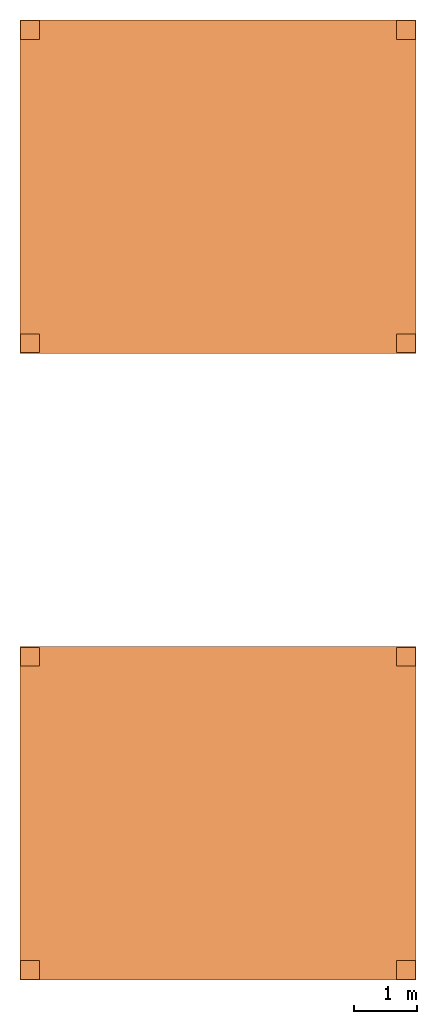
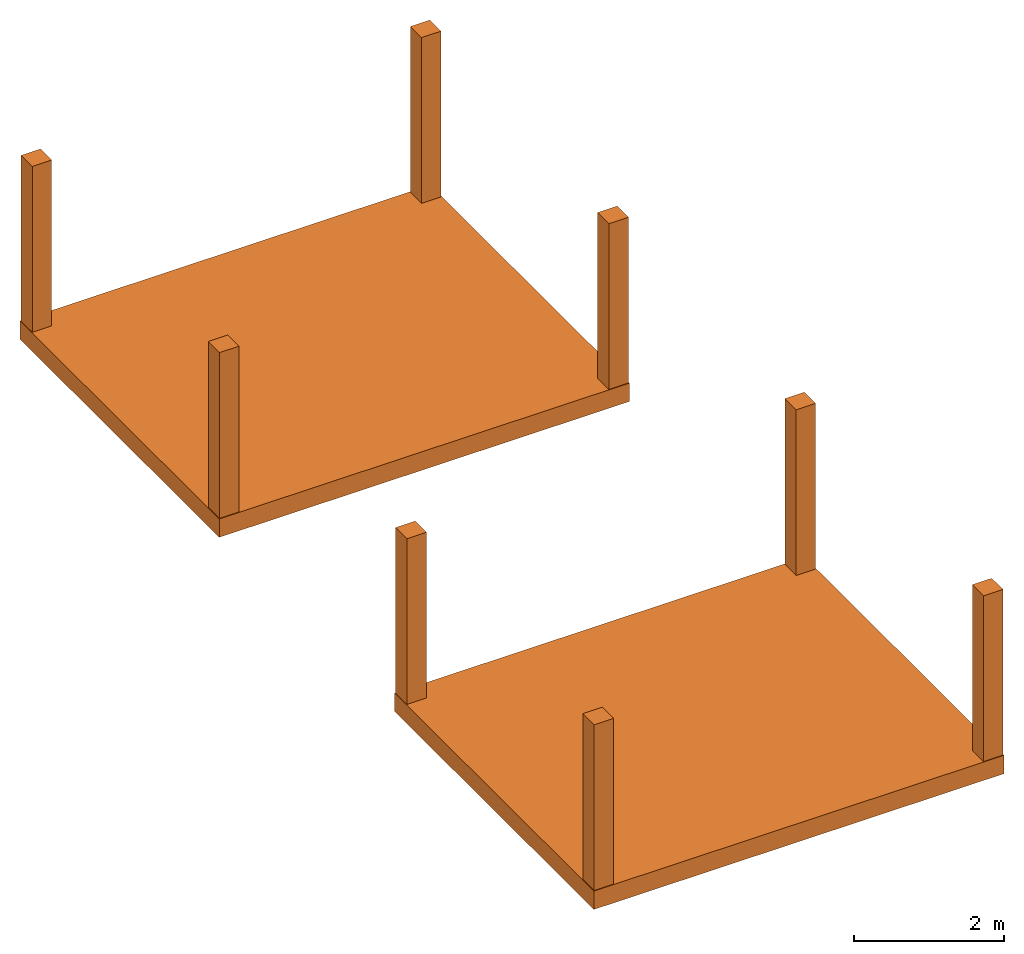
# One storey: 10 proxies.
"""IFC2X3 building model written with IfcOpenShell, lengths in metres."""

from ifc_helpers import new_model, entity, si_unit, converted_unit, derived_unit, money_unit, direction, frame, origin_with_axes, origin_2d_with_axis, place, context, subcontext, project, spatial, polyline, rectangle, outline, extrude, material, type_object, element, save


model = new_model("IFC2X3")

# Units and contexts
model_context = context("Model", 3, precision=1e-05, world=origin_with_axes(), true_north=direction((0.0, 1.0)))
body_context = subcontext(model_context, "Body", "Model", "MODEL_VIEW")
ifc_project = project(units=[si_unit("LENGTHUNIT", "METRE"), si_unit("AREAUNIT", "SQUARE_METRE"), si_unit("VOLUMEUNIT", "CUBIC_METRE"), converted_unit("PLANEANGLEUNIT", "DEGREE", entity("IfcPlaneAngleMeasure", 0.0174532925199433), si_unit("PLANEANGLEUNIT", "RADIAN"), dimensions=[0, 0, 0, 0, 0, 0, 0]), money_unit("EUR"), converted_unit("TIMEUNIT", "Year", entity("IfcTimeMeasure", 31557600.0), si_unit("TIMEUNIT", "SECOND"), dimensions=[0, 0, 1, 0, 0, 0, 0]), si_unit("MASSUNIT", "GRAM", prefix="KILO"), si_unit("THERMODYNAMICTEMPERATUREUNIT", "DEGREE_CELSIUS"), si_unit("LUMINOUSINTENSITYUNIT", "LUMEN"), si_unit("ENERGYUNIT", "JOULE", prefix="MEGA"), derived_unit("THERMALCONDUCTANCEUNIT", [(si_unit("POWERUNIT", "WATT"), 1), (si_unit("LENGTHUNIT", "METRE"), -1), (si_unit("THERMODYNAMICTEMPERATUREUNIT", "KELVIN"), -1)]), derived_unit("SPECIFICHEATCAPACITYUNIT", [(si_unit("ENERGYUNIT", "JOULE"), 1), (si_unit("MASSUNIT", "GRAM", prefix="KILO"), -1), (si_unit("THERMODYNAMICTEMPERATUREUNIT", "KELVIN"), -1)]), derived_unit("MASSDENSITYUNIT", [(si_unit("MASSUNIT", "GRAM", prefix="KILO"), 1), (si_unit("VOLUMEUNIT", "CUBIC_METRE"), -1)])], contexts=[model_context])

# Site, building, storey
site_placement = place(None, origin_with_axes())
site = spatial("IfcSite", under=ifc_project, at=site_placement, CompositionType="ELEMENT")
building_placement = place(site_placement, origin_with_axes())
building = spatial("IfcBuilding", under=site, at=building_placement, Name="Edificio", CompositionType="ELEMENT")
storey_placement = place(building_placement, frame((0.0, 0.0, 6.0), z_axis=(0.0, 0.0, 1.0), x_axis=(1.0, 0.0, 0.0)))
storey = spatial("IfcBuildingStorey", under=building, at=storey_placement, Name="L02", CompositionType="ELEMENT", Elevation=6.0)

# Proxies
ifc_material_1 = material(Name="Cemento - Strutturale")
building_element_proxy_type_1 = type_object("IfcBuildingElementProxyType", Name="Cemento - Strutturale 300", PredefinedType="NOTDEFINED")
for number, where, z_axis, x_axis, name in (
    (1, (-0.16, -0.16, 0.0), (0.0, 0.0, 1.0), (1.0, 0.0, 0.0), "SOL_002"),
    (2, (-0.1599999999999991, 9.84, 0.0), (0.0, 0.0, 1.0), (1.0, 0.0, 0.0), "SOL_006"),
):
    element("IfcBuildingElementProxy", number, at=place(storey_placement, frame(where, z_axis=z_axis, x_axis=x_axis)), inside=storey, type_object=building_element_proxy_type_1, material=ifc_material_1, Name=name, context=body_context, shape_type="SweptSolid", body=[
        extrude(outline(polyline([(0.0, 0.0), (6.32, 0.0), (6.32, 5.32), (0.0, 5.32), (0.0, 0.0)])), frame((0.0, 0.0, -0.3), z_axis=(0.0, 0.0, 1.0), x_axis=(1.0, 0.0, 0.0)), (0.0, 0.0, 1.0), 0.3),
    ])
ifc_material_2 = material(Name="Cemento Strutturale")
building_element_proxy_type_2 = type_object("IfcBuildingElementProxyType", Name="Cemento Strutturale 300 x 300", PredefinedType="NOTDEFINED")
for number, where, z_axis, x_axis, name in (
    (3, (6.0, 5.0, 0.0), (0.0, 0.0, 1.0), (1.0, 0.0, 0.0), "PIL_008"),
    (4, (0.0, 5.0, 0.0), (0.0, 0.0, 1.0), (1.0, 0.0, 0.0), "PIL_007"),
    (5, (6.0, 0.0, 0.0), (0.0, 0.0, 1.0), (1.0, 0.0, 0.0), "PIL_006"),
    (6, (0.0, 0.0, 0.0), (0.0, 0.0, 1.0), (1.0, 0.0, 0.0), "PIL_005"),
    (7, (0.0, 10.0, 0.0), (0.0, 0.0, 1.0), (1.0, 0.0, 0.0), "PIL_013"),
    (8, (6.000000000000001, 10.0, 0.0), (0.0, 0.0, 1.0), (1.0, 0.0, 0.0), "PIL_014"),
    (9, (0.0, 15.0, 0.0), (0.0, 0.0, 1.0), (1.0, 0.0, 0.0), "PIL_015"),
    (10, (6.000000000000001, 15.0, 0.0), (0.0, 0.0, 1.0), (1.0, 0.0, 0.0), "PIL_016"),
):
    element("IfcBuildingElementProxy", number, at=place(storey_placement, frame(where, z_axis=z_axis, x_axis=x_axis)), inside=storey, type_object=building_element_proxy_type_2, material=ifc_material_2, Name=name, context=body_context, shape_type="SweptSolid", body=[
        extrude(rectangle(XDim=0.3, YDim=0.3, at=origin_2d_with_axis()), origin_with_axes(), (0.0, 0.0, 1.0), 2.699999999999999),
    ])

save(model, "model.ifc")
